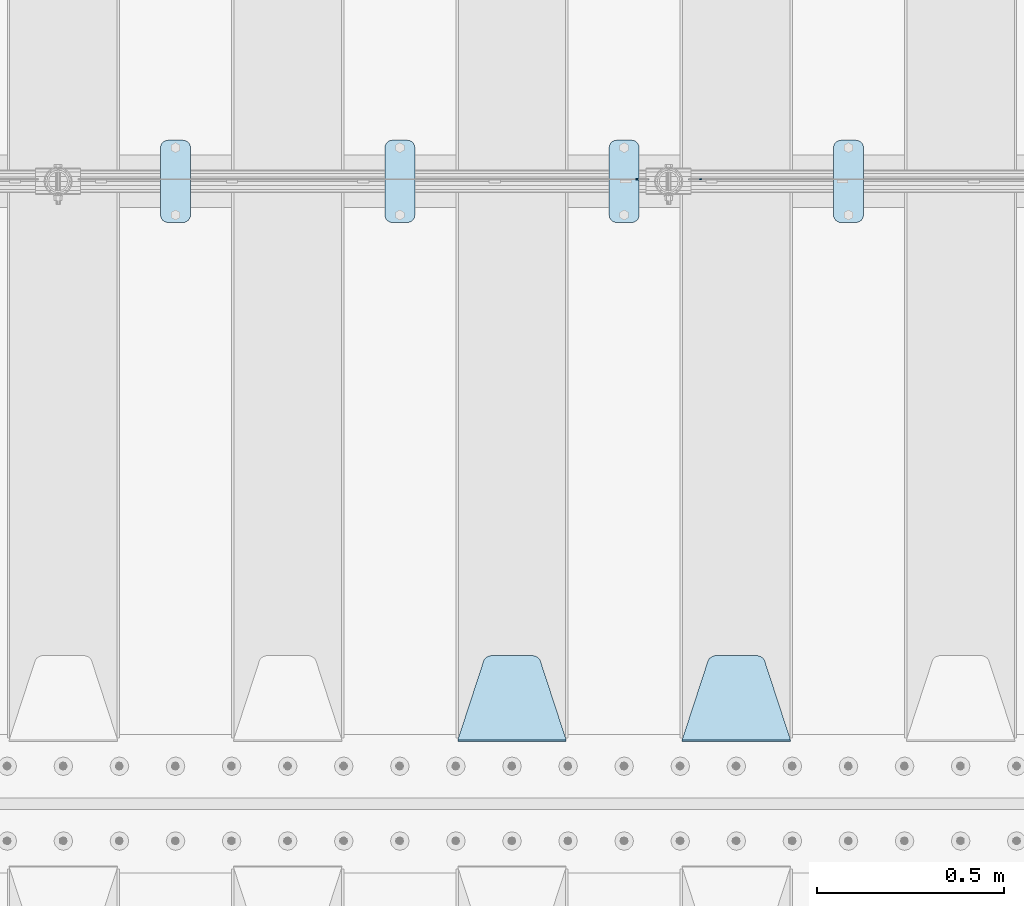
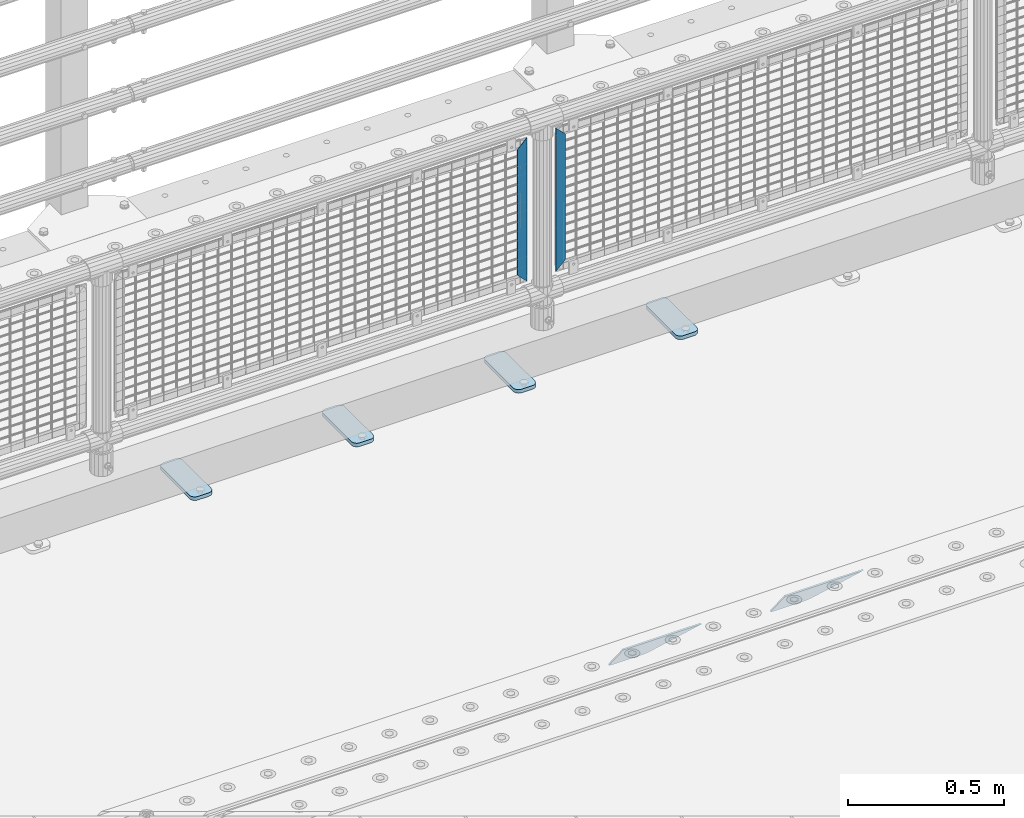
# One storey, part 211 of 242: 8 plates.
"""IFC2X3 building model written with IfcOpenShell, lengths in millimetres."""

import ifcopenshell
import ifcopenshell.guid

model = None  # the IFC model being written
_history = None  # IfcOwnerHistory: only IFC2X3 demands one
_inside = {}  # id of a spatial element -> (the spatial element, [elements in it])
_under = {}  # id of a project, library or spatial element -> (it, [spatial elements below it])
_declared = {}  # id of a project -> (the project, [libraries it declares])
_typed = {}  # id of a type object -> (the type object, [elements of that type])
_made_of = {}  # id of a material, layer set ... -> (it, [elements and type objects made of it])


def new_model(schema):
    """Start an empty IFC model of exactly this schema.

    Asked for "IFC4X3", IfcOpenShell would pick the latest addendum, in which some entities
    have other attributes; the version numbers below select the first issue.
    IFC2X3 requires an IfcOwnerHistory on every rooted entity: one is made here for all.
    """
    global model, _history
    if schema == "IFC4X3":
        model = ifcopenshell.file(schema_version=(4, 3, 0, 0))
    else:
        model = ifcopenshell.file(schema=schema)
    _inside.clear()
    _under.clear()
    _declared.clear()
    _typed.clear()
    _made_of.clear()
    _history = None
    if model.schema == "IFC2X3":
        org = make("IfcOrganization", Name="unknown")
        user = make(
            "IfcPersonAndOrganization",
            ThePerson=make("IfcPerson", FamilyName="unknown"),
            TheOrganization=org,
        )
        app = make(
            "IfcApplication",
            ApplicationDeveloper=org,
            Version="unknown",
            ApplicationFullName="unknown",
            ApplicationIdentifier="unknown",
        )
        _history = make(
            "IfcOwnerHistory",
            OwningUser=user,
            OwningApplication=app,
            ChangeAction="ADDED",
            CreationDate=0,
        )
    return model


def make(cls, **values):
    """One entity of the class cls with the attributes given. An attribute that is None is left unset."""
    return model.create_entity(
        cls, **{name: value for name, value in values.items() if value is not None}
    )


def rooted(cls, **values):
    """An entity with a GlobalId (a new one), such as an element, a storey or a relation."""
    return make(cls, GlobalId=ifcopenshell.guid.new(), OwnerHistory=_history, **values)


def si_unit(unit_type, name, prefix=None):
    """IfcSIUnit, for example si_unit("LENGTHUNIT", "METRE", prefix="MILLI")."""
    return make("IfcSIUnit", UnitType=unit_type, Prefix=prefix, Name=name)


def assignment(units):
    """IfcUnitAssignment: the units of a project."""
    return None if units is None else make("IfcUnitAssignment", Units=units)


def point(xyz):
    """IfcCartesianPoint."""
    return None if xyz is None else make("IfcCartesianPoint", Coordinates=xyz)


def direction(xyz):
    """IfcDirection."""
    return None if xyz is None else make("IfcDirection", DirectionRatios=xyz)


def frame(location, z_axis=None, x_axis=None):
    """IfcAxis2Placement3D, a coordinate frame: its origin and axes. An axis left out is left unset."""
    return make(
        "IfcAxis2Placement3D",
        Location=point(location),
        Axis=direction(z_axis),
        RefDirection=direction(x_axis),
    )


def origin_with_axes():
    """The frame at (0, 0, 0) with the z axis (0, 0, 1) and the x axis (1, 0, 0) written out."""
    return frame((0.0, 0.0, 0.0), z_axis=(0.0, 0.0, 1.0), x_axis=(1.0, 0.0, 0.0))


def place(relative_to, where):
    """IfcLocalPlacement: puts the frame where relative to a parent placement (None: the world)."""
    return make(
        "IfcLocalPlacement", PlacementRelTo=relative_to, RelativePlacement=where
    )


def context(
    kind, dimensions, precision=None, world=None, true_north=None, identifier=None
):
    """IfcGeometricRepresentationContext, for example the 3D "Model" context."""
    return make(
        "IfcGeometricRepresentationContext",
        ContextIdentifier=identifier,
        ContextType=kind,
        CoordinateSpaceDimension=dimensions,
        Precision=precision,
        WorldCoordinateSystem=world,
        TrueNorth=true_north,
    )


def subcontext(parent, identifier, kind, view, scale=None):
    """IfcGeometricRepresentationSubContext, for example "Body" below "Model"."""
    return make(
        "IfcGeometricRepresentationSubContext",
        ContextIdentifier=identifier,
        ContextType=kind,
        ParentContext=parent,
        TargetScale=scale,
        TargetView=view,
    )


def project(units=None, contexts=None):
    """IfcProject with its units and contexts."""
    return rooted(
        "IfcProject",
        Name="project",
        RepresentationContexts=contexts,
        UnitsInContext=assignment(units),
    )


def spatial(cls, under=None, at=None, **own):
    """A site, building, storey or space (cls), placed at a placement, below another one or the project."""
    s = rooted(cls, ObjectPlacement=at, **own)
    if under is not None:
        _under.setdefault(under.id(), (under, []))[1].append(s)
    return s


def faces_of(points, faces, orient=None, outer=None):
    """IfcFace entities. A face is a list of loops; a loop is a list of indices into points, from 0.

    orient and outer hold one flag for each loop. By default every Orientation is true, the
    first loop of a face is its IfcFaceOuterBound and the others are IfcFaceBound.
    """
    made = []
    for i, loops in enumerate(faces):
        bounds = []
        for j, loop in enumerate(loops):
            is_outer = j == 0 if outer is None else outer[i][j]
            bounds.append(
                make(
                    "IfcFaceOuterBound" if is_outer else "IfcFaceBound",
                    Bound=make("IfcPolyLoop", Polygon=[points[k] for k in loop]),
                    Orientation=True if orient is None else orient[i][j],
                )
            )
        made.append(make("IfcFace", Bounds=bounds))
    return made


def faceted_brep(points, faces, orient=None, outer=None, voids=None):
    """IfcFacetedBrep: a solid bounded by flat faces; with voids (closed shells), ...WithVoids."""
    shared = [point(p) for p in points]
    hull = make("IfcClosedShell", CfsFaces=faces_of(shared, faces, orient, outer))
    if voids is None:
        return make("IfcFacetedBrep", Outer=hull)
    return make(
        "IfcFacetedBrepWithVoids",
        Outer=hull,
        Voids=[
            make(cls, CfsFaces=faces_of(shared, fs, o, b)) for cls, fs, o, b in voids
        ],
    )


def shape(context_of_items, identifier, shape_type, items):
    """IfcShapeRepresentation: the items that make up one representation, for example the "Body"."""
    return make(
        "IfcShapeRepresentation",
        ContextOfItems=context_of_items,
        RepresentationIdentifier=identifier,
        RepresentationType=shape_type,
        Items=items,
    )


def material(Name=None, Category=None):
    """IfcMaterial."""
    return make("IfcMaterial", Name=Name, Category=Category)


def made_of(thing, what):
    """Note that an element or type object is made of a material, layer set ...; save() writes the relation."""
    if what is not None:
        _made_of.setdefault(what.id(), (what, []))[1].append(thing)
    return thing


def type_object(cls, material=None, **own):
    """A type object (cls), such as IfcWallType, which elements share."""
    return made_of(rooted(cls, **own), material)


def element(
    cls,
    number,
    at=None,
    inside=None,
    cuts=None,
    type_object=None,
    material=None,
    context=None,
    identifier="Body",
    shape_type=None,
    held_by="IfcProductDefinitionShape",
    body=None,
    shapes=None,
    **own,
):
    """One element of the class cls, such as IfcWall. Its Tag is "e" and its number.

    at: its placement. inside: the storey or other place that contains it. cuts: it is an
    opening in that element (IfcRelVoidsElement). A single representation is given by context,
    identifier, shape_type and body (its items); several are given by shapes. held_by: the class
    of the entity that holds the representations. save() writes the other relations.
    """
    e = rooted(cls, Tag="e%d" % number, ObjectPlacement=at, **own)
    if body is not None:
        shapes = [shape(context, identifier, shape_type, body)]
    if shapes is not None:
        e.Representation = make(held_by, Representations=shapes)
    if inside is not None:
        _inside.setdefault(inside.id(), (inside, []))[1].append(e)
    if cuts is not None:
        rooted(
            "IfcRelVoidsElement", RelatingBuildingElement=cuts, RelatedOpeningElement=e
        )
    if type_object is not None:
        _typed.setdefault(type_object.id(), (type_object, []))[1].append(e)
    return made_of(e, material)


def aggregate(whole, parts):
    """IfcRelAggregates: a whole, such as a stair, and the parts it consists of."""
    return rooted("IfcRelAggregates", RelatingObject=whole, RelatedObjects=parts)


def save(model, path):
    """Write the relations noted so far, then the file.

    IfcRelAggregates (storeys below a building ...), IfcRelContainedInSpatialStructure (elements
    in a storey), IfcRelDefinesByType, IfcRelAssociatesMaterial and IfcRelDeclares: one each for
    every whole, place, type object, material and project.
    """
    for whole, parts in _under.values():
        aggregate(whole, parts)
    for where, things in _inside.values():
        rooted(
            "IfcRelContainedInSpatialStructure",
            RelatedElements=things,
            RelatingStructure=where,
        )
    for kind, things in _typed.values():
        rooted("IfcRelDefinesByType", RelatedObjects=things, RelatingType=kind)
    for what, things in _made_of.values():
        rooted("IfcRelAssociatesMaterial", RelatedObjects=things, RelatingMaterial=what)
    for by, libraries in _declared.values():
        rooted("IfcRelDeclares", RelatingContext=by, RelatedDefinitions=libraries)
    model.write(path)


model = new_model("IFC2X3")

# Units and contexts
model_context = context("Model", 3, precision=1e-05, world=origin_with_axes())
body_context = subcontext(model_context, "Body", "Model", "MODEL_VIEW")
ifc_project = project(units=[si_unit("LENGTHUNIT", "METRE", prefix="MILLI"), si_unit("AREAUNIT", "SQUARE_METRE"), si_unit("VOLUMEUNIT", "CUBIC_METRE"), si_unit("MASSUNIT", "GRAM", prefix="KILO"), si_unit("TIMEUNIT", "SECOND"), si_unit("PLANEANGLEUNIT", "RADIAN"), si_unit("SOLIDANGLEUNIT", "STERADIAN"), si_unit("THERMODYNAMICTEMPERATUREUNIT", "DEGREE_CELSIUS"), si_unit("LUMINOUSINTENSITYUNIT", "LUMEN")], contexts=[model_context])

# Site, building, storey
site_placement = place(None, origin_with_axes())
site = spatial("IfcSite", under=ifc_project, at=site_placement, CompositionType="ELEMENT")
building_placement = place(site_placement, origin_with_axes())
building = spatial("IfcBuilding", under=site, at=building_placement, Name="Standard", CompositionType="ELEMENT")
storey_placement = place(building_placement, origin_with_axes())
storey = spatial("IfcBuildingStorey", under=building, at=storey_placement, Name="Undefined", CompositionType="ELEMENT", Elevation=0.0)

# Plates
ifc_material_1 = material(Name="Misc_Undefined")
plate_type_1 = type_object("IfcPlateType", PredefinedType="NOTDEFINED")
plate_1_placement = place(storey_placement, frame((-31942.490286459, -19329.5, 879.519963133601), z_axis=(-0.707008801899319, 0.0, -0.707204746899291), x_axis=(-0.707204746899296, 0.0, 0.707008801899313)))
element("IfcPlate", 1, at=plate_1_placement, inside=storey, type_object=plate_type_1, material=ifc_material_1, context=body_context, shape_type="Brep", body=[
    faceted_brep([(0.0, -1.50000000000364, 0.0), (-348.552185058597, -1.5, 348.655029296875), (-348.552185058597, 1.5, 348.655029296875), (-3.63797880709171e-12, 1.49999999999636, 0.0), (-348.544891357426, -1.5, 398.152496337891), (-348.544891357426, 1.5, 398.152496337891), (49.5043945312464, -1.5, 8.00355337560177e-11), (49.5043945312464, 1.5, 8.00355337560177e-11)], [[[0, 1, 2, 3]], [[1, 4, 5, 2]], [[4, 6, 7, 5]], [[6, 0, 3, 7]], [[5, 7, 3, 2]], [[6, 4, 1, 0]]]),
])
plate_2_placement = place(storey_placement, frame((-32119.5003125164, -19329.5, 879.52), z_axis=(0.707103624179499, 0.0, -0.707109938179501), x_axis=(0.707109938179508, 0.0, 0.707103624179492)))
element("IfcPlate", 2, at=plate_2_placement, inside=storey, type_object=plate_type_1, material=ifc_material_1, context=body_context, shape_type="Brep", body=[
    faceted_brep([(0.0, -1.50000000000364, 0.0), (-348.605163574222, -1.5, 348.602081298832), (-348.605163574222, 1.5, 348.602081298832), (-3.63797880709171e-12, 1.49999999999636, 0.0), (-348.605163574222, -1.5, 398.099334716801), (-348.605163574222, 1.5, 398.099334716801), (49.4976959228534, -1.5, -3.63797880709171e-12), (49.4976959228534, 1.5, -3.63797880709171e-12)], [[[0, 1, 2, 3]], [[1, 4, 5, 2]], [[4, 6, 7, 5]], [[6, 0, 3, 7]], [[5, 7, 3, 2]], [[6, 4, 1, 0]]]),
])
ifc_material_2 = material(Name="STEEL/S355J2")
plate_type_2 = type_object("IfcPlateType", PredefinedType="NOTDEFINED")
plate_3_placement = place(storey_placement, frame((-31590.0, -19225.5, 21.0199999999977), z_axis=(1.0, 0.0, 0.0), x_axis=(0.0, -1.0, 0.0)))
element("IfcPlate", 3, at=plate_3_placement, inside=storey, type_object=plate_type_2, material=ifc_material_2, context=body_context, shape_type="Brep", body=[
    faceted_brep([(0.0, -7.0, 20.0), (0.0, -7.0, 60.0), (0.0, 7.0, 60.0), (0.0, 7.0, 20.0), (0.384294391937146, -7.0, 63.9018064403208), (0.384294391937146, 7.0, 63.9018064403208), (1.52240934977453, -7.0, 67.6536686473009), (1.52240934977453, 7.0, 67.6536686473009), (3.37060775395003, -7.0, 71.1114046603907), (3.37060775395003, 7.0, 71.1114046603907), (5.8578643762703, -7.0, 74.1421356237297), (5.8578643762703, 7.0, 74.1421356237297), (8.88859533960931, -7.0, 76.62939224605), (8.88859533960931, 7.0, 76.62939224605), (12.3463313526991, -7.0, 78.4775906502255), (12.3463313526991, 7.0, 78.4775906502255), (16.0981935596792, -7.0, 79.6157056080629), (16.0981935596792, 7.0, 79.6157056080629), (20.0, -7.0, 80.0), (20.0, 7.0, 80.0), (200.0, -7.0, 80.0), (200.0, 7.0, 80.0), (203.901806440321, -7.0, 79.6157056080629), (203.901806440321, 7.0, 79.6157056080629), (207.653668647301, -7.0, 78.4775906502255), (207.653668647301, 7.0, 78.4775906502255), (211.111404660391, -7.0, 76.62939224605), (211.111404660391, 7.0, 76.62939224605), (214.14213562373, -7.0, 74.1421356237297), (214.14213562373, 7.0, 74.1421356237297), (216.62939224605, -7.0, 71.1114046603907), (216.62939224605, 7.0, 71.1114046603907), (218.477590650225, -7.0, 67.6536686473009), (218.477590650225, 7.0, 67.6536686473009), (219.615705608063, -7.0, 63.9018064403208), (219.615705608063, 7.0, 63.9018064403208), (220.0, -7.0, 60.0), (220.0, 7.0, 60.0), (220.0, -7.0, 20.0), (220.0, 7.0, 20.0), (219.615705608063, -7.0, 16.0981935596792), (219.615705608063, 7.0, 16.0981935596792), (218.477590650225, -7.0, 12.3463313526991), (218.477590650225, 7.0, 12.3463313526991), (216.62939224605, -7.0, 8.88859533960931), (216.62939224605, 7.0, 8.88859533960931), (214.14213562373, -7.0, 5.8578643762703), (214.14213562373, 7.0, 5.8578643762703), (211.111404660391, -7.0, 3.37060775395003), (211.111404660391, 7.0, 3.37060775395003), (207.653668647301, -7.0, 1.52240934977453), (207.653668647301, 7.0, 1.52240934977453), (203.901806440321, -7.0, 0.384294391937146), (203.901806440321, 7.0, 0.384294391937146), (200.0, -7.0, 0.0), (200.0, 7.0, 0.0), (20.0, -7.0, 0.0), (20.0, 7.0, 0.0), (16.0981935596792, -7.0, 0.384294391937146), (16.0981935596792, 7.0, 0.384294391937146), (12.3463313526991, -7.0, 1.52240934977453), (12.3463313526991, 7.0, 1.52240934977453), (8.88859533960931, -7.0, 3.37060775395003), (8.88859533960931, 7.0, 3.37060775395003), (5.8578643762703, -7.0, 5.8578643762703), (5.8578643762703, 7.0, 5.8578643762703), (3.37060775395003, -7.0, 8.88859533960931), (3.37060775395003, 7.0, 8.88859533960931), (1.52240934977453, -7.0, 12.3463313526991), (1.52240934977453, 7.0, 12.3463313526991), (0.384294391937146, -7.0, 16.0981935596792), (0.384294391937146, 7.0, 16.0981935596792)], [[[0, 1, 2, 3]], [[1, 4, 5, 2]], [[4, 6, 7, 5]], [[6, 8, 9, 7]], [[8, 10, 11, 9]], [[10, 12, 13, 11]], [[12, 14, 15, 13]], [[14, 16, 17, 15]], [[16, 18, 19, 17]], [[18, 20, 21, 19]], [[20, 22, 23, 21]], [[22, 24, 25, 23]], [[24, 26, 27, 25]], [[26, 28, 29, 27]], [[28, 30, 31, 29]], [[30, 32, 33, 31]], [[32, 34, 35, 33]], [[34, 36, 37, 35]], [[36, 38, 39, 37]], [[38, 40, 41, 39]], [[40, 42, 43, 41]], [[42, 44, 45, 43]], [[44, 46, 47, 45]], [[46, 48, 49, 47]], [[48, 50, 51, 49]], [[50, 52, 53, 51]], [[52, 54, 55, 53]], [[54, 56, 57, 55]], [[56, 58, 59, 57]], [[58, 60, 61, 59]], [[60, 62, 63, 61]], [[62, 64, 65, 63]], [[64, 66, 67, 65]], [[66, 68, 69, 67]], [[68, 70, 71, 69]], [[70, 0, 3, 71]], [[5, 7, 9, 11, 13, 15, 17, 19, 21, 23, 25, 27, 29, 31, 33, 35, 37, 39, 41, 43, 45, 47, 49, 51, 53, 55, 57, 59, 61, 63, 65, 67, 69, 71, 3, 2]], [[70, 68, 66, 64, 62, 60, 58, 56, 54, 52, 50, 48, 46, 44, 42, 40, 38, 36, 34, 32, 30, 28, 26, 24, 22, 20, 18, 16, 14, 12, 10, 8, 6, 4, 1, 0]]]),
])
plate_4_placement = place(storey_placement, frame((-32190.0, -19225.5, 21.0199999999977), z_axis=(1.0, 0.0, 0.0), x_axis=(0.0, -1.0, 0.0)))
element("IfcPlate", 4, at=plate_4_placement, inside=storey, type_object=plate_type_2, material=ifc_material_2, context=body_context, shape_type="Brep", body=[
    faceted_brep([(0.0, -7.0, 20.0), (0.0, -7.0, 60.0), (0.0, 7.0, 60.0), (0.0, 7.0, 20.0), (0.384294391937146, -7.0, 63.9018064403208), (0.384294391937146, 7.0, 63.9018064403208), (1.52240934977453, -7.0, 67.6536686473009), (1.52240934977453, 7.0, 67.6536686473009), (3.37060775395003, -7.0, 71.1114046603907), (3.37060775395003, 7.0, 71.1114046603907), (5.8578643762703, -7.0, 74.1421356237297), (5.8578643762703, 7.0, 74.1421356237297), (8.88859533960931, -7.0, 76.62939224605), (8.88859533960931, 7.0, 76.62939224605), (12.3463313526991, -7.0, 78.4775906502255), (12.3463313526991, 7.0, 78.4775906502255), (16.0981935596792, -7.0, 79.6157056080629), (16.0981935596792, 7.0, 79.6157056080629), (20.0, -7.0, 80.0), (20.0, 7.0, 80.0), (200.0, -7.0, 80.0), (200.0, 7.0, 80.0), (203.901806440321, -7.0, 79.6157056080629), (203.901806440321, 7.0, 79.6157056080629), (207.653668647301, -7.0, 78.4775906502255), (207.653668647301, 7.0, 78.4775906502255), (211.111404660391, -7.0, 76.62939224605), (211.111404660391, 7.0, 76.62939224605), (214.14213562373, -7.0, 74.1421356237297), (214.14213562373, 7.0, 74.1421356237297), (216.62939224605, -7.0, 71.1114046603907), (216.62939224605, 7.0, 71.1114046603907), (218.477590650225, -7.0, 67.6536686473009), (218.477590650225, 7.0, 67.6536686473009), (219.615705608063, -7.0, 63.9018064403208), (219.615705608063, 7.0, 63.9018064403208), (220.0, -7.0, 60.0), (220.0, 7.0, 60.0), (220.0, -7.0, 20.0), (220.0, 7.0, 20.0), (219.615705608063, -7.0, 16.0981935596792), (219.615705608063, 7.0, 16.0981935596792), (218.477590650225, -7.0, 12.3463313526991), (218.477590650225, 7.0, 12.3463313526991), (216.62939224605, -7.0, 8.88859533960931), (216.62939224605, 7.0, 8.88859533960931), (214.14213562373, -7.0, 5.8578643762703), (214.14213562373, 7.0, 5.8578643762703), (211.111404660391, -7.0, 3.37060775395003), (211.111404660391, 7.0, 3.37060775395003), (207.653668647301, -7.0, 1.52240934977453), (207.653668647301, 7.0, 1.52240934977453), (203.901806440321, -7.0, 0.384294391937146), (203.901806440321, 7.0, 0.384294391937146), (200.0, -7.0, 0.0), (200.0, 7.0, 0.0), (20.0, -7.0, 0.0), (20.0, 7.0, 0.0), (16.0981935596792, -7.0, 0.384294391937146), (16.0981935596792, 7.0, 0.384294391937146), (12.3463313526991, -7.0, 1.52240934977453), (12.3463313526991, 7.0, 1.52240934977453), (8.88859533960931, -7.0, 3.37060775395003), (8.88859533960931, 7.0, 3.37060775395003), (5.8578643762703, -7.0, 5.8578643762703), (5.8578643762703, 7.0, 5.8578643762703), (3.37060775395003, -7.0, 8.88859533960931), (3.37060775395003, 7.0, 8.88859533960931), (1.52240934977453, -7.0, 12.3463313526991), (1.52240934977453, 7.0, 12.3463313526991), (0.384294391937146, -7.0, 16.0981935596792), (0.384294391937146, 7.0, 16.0981935596792)], [[[0, 1, 2, 3]], [[1, 4, 5, 2]], [[4, 6, 7, 5]], [[6, 8, 9, 7]], [[8, 10, 11, 9]], [[10, 12, 13, 11]], [[12, 14, 15, 13]], [[14, 16, 17, 15]], [[16, 18, 19, 17]], [[18, 20, 21, 19]], [[20, 22, 23, 21]], [[22, 24, 25, 23]], [[24, 26, 27, 25]], [[26, 28, 29, 27]], [[28, 30, 31, 29]], [[30, 32, 33, 31]], [[32, 34, 35, 33]], [[34, 36, 37, 35]], [[36, 38, 39, 37]], [[38, 40, 41, 39]], [[40, 42, 43, 41]], [[42, 44, 45, 43]], [[44, 46, 47, 45]], [[46, 48, 49, 47]], [[48, 50, 51, 49]], [[50, 52, 53, 51]], [[52, 54, 55, 53]], [[54, 56, 57, 55]], [[56, 58, 59, 57]], [[58, 60, 61, 59]], [[60, 62, 63, 61]], [[62, 64, 65, 63]], [[64, 66, 67, 65]], [[66, 68, 69, 67]], [[68, 70, 71, 69]], [[70, 0, 3, 71]], [[5, 7, 9, 11, 13, 15, 17, 19, 21, 23, 25, 27, 29, 31, 33, 35, 37, 39, 41, 43, 45, 47, 49, 51, 53, 55, 57, 59, 61, 63, 65, 67, 69, 71, 3, 2]], [[70, 68, 66, 64, 62, 60, 58, 56, 54, 52, 50, 48, 46, 44, 42, 40, 38, 36, 34, 32, 30, 28, 26, 24, 22, 20, 18, 16, 14, 12, 10, 8, 6, 4, 1, 0]]]),
])
plate_5_placement = place(storey_placement, frame((-32790.0, -19225.5, 21.0199999999977), z_axis=(1.0, 0.0, 0.0), x_axis=(0.0, -1.0, 0.0)))
element("IfcPlate", 5, at=plate_5_placement, inside=storey, type_object=plate_type_2, material=ifc_material_2, context=body_context, shape_type="Brep", body=[
    faceted_brep([(0.0, -7.0, 20.0), (0.0, -7.0, 60.0), (0.0, 7.0, 60.0), (0.0, 7.0, 20.0), (0.384294391937146, -7.0, 63.9018064403208), (0.384294391937146, 7.0, 63.9018064403208), (1.52240934977453, -7.0, 67.6536686473009), (1.52240934977453, 7.0, 67.6536686473009), (3.37060775395003, -7.0, 71.1114046603907), (3.37060775395003, 7.0, 71.1114046603907), (5.8578643762703, -7.0, 74.1421356237297), (5.8578643762703, 7.0, 74.1421356237297), (8.88859533960931, -7.0, 76.62939224605), (8.88859533960931, 7.0, 76.62939224605), (12.3463313526991, -7.0, 78.4775906502255), (12.3463313526991, 7.0, 78.4775906502255), (16.0981935596792, -7.0, 79.6157056080629), (16.0981935596792, 7.0, 79.6157056080629), (20.0, -7.0, 80.0), (20.0, 7.0, 80.0), (200.0, -7.0, 80.0), (200.0, 7.0, 80.0), (203.901806440321, -7.0, 79.6157056080629), (203.901806440321, 7.0, 79.6157056080629), (207.653668647301, -7.0, 78.4775906502255), (207.653668647301, 7.0, 78.4775906502255), (211.111404660391, -7.0, 76.62939224605), (211.111404660391, 7.0, 76.62939224605), (214.14213562373, -7.0, 74.1421356237297), (214.14213562373, 7.0, 74.1421356237297), (216.62939224605, -7.0, 71.1114046603907), (216.62939224605, 7.0, 71.1114046603907), (218.477590650225, -7.0, 67.6536686473009), (218.477590650225, 7.0, 67.6536686473009), (219.615705608063, -7.0, 63.9018064403208), (219.615705608063, 7.0, 63.9018064403208), (220.0, -7.0, 60.0), (220.0, 7.0, 60.0), (220.0, -7.0, 20.0), (220.0, 7.0, 20.0), (219.615705608063, -7.0, 16.0981935596792), (219.615705608063, 7.0, 16.0981935596792), (218.477590650225, -7.0, 12.3463313526991), (218.477590650225, 7.0, 12.3463313526991), (216.62939224605, -7.0, 8.88859533960931), (216.62939224605, 7.0, 8.88859533960931), (214.14213562373, -7.0, 5.8578643762703), (214.14213562373, 7.0, 5.8578643762703), (211.111404660391, -7.0, 3.37060775395003), (211.111404660391, 7.0, 3.37060775395003), (207.653668647301, -7.0, 1.52240934977453), (207.653668647301, 7.0, 1.52240934977453), (203.901806440321, -7.0, 0.384294391937146), (203.901806440321, 7.0, 0.384294391937146), (200.0, -7.0, 0.0), (200.0, 7.0, 0.0), (20.0, -7.0, 0.0), (20.0, 7.0, 0.0), (16.0981935596792, -7.0, 0.384294391937146), (16.0981935596792, 7.0, 0.384294391937146), (12.3463313526991, -7.0, 1.52240934977453), (12.3463313526991, 7.0, 1.52240934977453), (8.88859533960931, -7.0, 3.37060775395003), (8.88859533960931, 7.0, 3.37060775395003), (5.8578643762703, -7.0, 5.8578643762703), (5.8578643762703, 7.0, 5.8578643762703), (3.37060775395003, -7.0, 8.88859533960931), (3.37060775395003, 7.0, 8.88859533960931), (1.52240934977453, -7.0, 12.3463313526991), (1.52240934977453, 7.0, 12.3463313526991), (0.384294391937146, -7.0, 16.0981935596792), (0.384294391937146, 7.0, 16.0981935596792)], [[[0, 1, 2, 3]], [[1, 4, 5, 2]], [[4, 6, 7, 5]], [[6, 8, 9, 7]], [[8, 10, 11, 9]], [[10, 12, 13, 11]], [[12, 14, 15, 13]], [[14, 16, 17, 15]], [[16, 18, 19, 17]], [[18, 20, 21, 19]], [[20, 22, 23, 21]], [[22, 24, 25, 23]], [[24, 26, 27, 25]], [[26, 28, 29, 27]], [[28, 30, 31, 29]], [[30, 32, 33, 31]], [[32, 34, 35, 33]], [[34, 36, 37, 35]], [[36, 38, 39, 37]], [[38, 40, 41, 39]], [[40, 42, 43, 41]], [[42, 44, 45, 43]], [[44, 46, 47, 45]], [[46, 48, 49, 47]], [[48, 50, 51, 49]], [[50, 52, 53, 51]], [[52, 54, 55, 53]], [[54, 56, 57, 55]], [[56, 58, 59, 57]], [[58, 60, 61, 59]], [[60, 62, 63, 61]], [[62, 64, 65, 63]], [[64, 66, 67, 65]], [[66, 68, 69, 67]], [[68, 70, 71, 69]], [[70, 0, 3, 71]], [[5, 7, 9, 11, 13, 15, 17, 19, 21, 23, 25, 27, 29, 31, 33, 35, 37, 39, 41, 43, 45, 47, 49, 51, 53, 55, 57, 59, 61, 63, 65, 67, 69, 71, 3, 2]], [[70, 68, 66, 64, 62, 60, 58, 56, 54, 52, 50, 48, 46, 44, 42, 40, 38, 36, 34, 32, 30, 28, 26, 24, 22, 20, 18, 16, 14, 12, 10, 8, 6, 4, 1, 0]]]),
])
plate_6_placement = place(storey_placement, frame((-33390.0, -19225.5, 21.0199999999977), z_axis=(1.0, 0.0, 0.0), x_axis=(0.0, -1.0, 0.0)))
element("IfcPlate", 6, at=plate_6_placement, inside=storey, type_object=plate_type_2, material=ifc_material_2, context=body_context, shape_type="Brep", body=[
    faceted_brep([(0.0, -7.0, 20.0), (0.0, -7.0, 60.0), (0.0, 7.0, 60.0), (0.0, 7.0, 20.0), (0.384294391937146, -7.0, 63.9018064403208), (0.384294391937146, 7.0, 63.9018064403208), (1.52240934977453, -7.0, 67.6536686473009), (1.52240934977453, 7.0, 67.6536686473009), (3.37060775395003, -7.0, 71.1114046603907), (3.37060775395003, 7.0, 71.1114046603907), (5.8578643762703, -7.0, 74.1421356237297), (5.8578643762703, 7.0, 74.1421356237297), (8.88859533960931, -7.0, 76.62939224605), (8.88859533960931, 7.0, 76.62939224605), (12.3463313526991, -7.0, 78.4775906502255), (12.3463313526991, 7.0, 78.4775906502255), (16.0981935596792, -7.0, 79.6157056080629), (16.0981935596792, 7.0, 79.6157056080629), (20.0, -7.0, 80.0), (20.0, 7.0, 80.0), (200.0, -7.0, 80.0), (200.0, 7.0, 80.0), (203.901806440321, -7.0, 79.6157056080629), (203.901806440321, 7.0, 79.6157056080629), (207.653668647301, -7.0, 78.4775906502255), (207.653668647301, 7.0, 78.4775906502255), (211.111404660391, -7.0, 76.62939224605), (211.111404660391, 7.0, 76.62939224605), (214.14213562373, -7.0, 74.1421356237297), (214.14213562373, 7.0, 74.1421356237297), (216.62939224605, -7.0, 71.1114046603907), (216.62939224605, 7.0, 71.1114046603907), (218.477590650225, -7.0, 67.6536686473009), (218.477590650225, 7.0, 67.6536686473009), (219.615705608063, -7.0, 63.9018064403208), (219.615705608063, 7.0, 63.9018064403208), (220.0, -7.0, 60.0), (220.0, 7.0, 60.0), (220.0, -7.0, 20.0), (220.0, 7.0, 20.0), (219.615705608063, -7.0, 16.0981935596792), (219.615705608063, 7.0, 16.0981935596792), (218.477590650225, -7.0, 12.3463313526991), (218.477590650225, 7.0, 12.3463313526991), (216.62939224605, -7.0, 8.88859533960931), (216.62939224605, 7.0, 8.88859533960931), (214.14213562373, -7.0, 5.8578643762703), (214.14213562373, 7.0, 5.8578643762703), (211.111404660391, -7.0, 3.37060775395003), (211.111404660391, 7.0, 3.37060775395003), (207.653668647301, -7.0, 1.52240934977453), (207.653668647301, 7.0, 1.52240934977453), (203.901806440321, -7.0, 0.384294391937146), (203.901806440321, 7.0, 0.384294391937146), (200.0, -7.0, 0.0), (200.0, 7.0, 0.0), (20.0, -7.0, 0.0), (20.0, 7.0, 0.0), (16.0981935596792, -7.0, 0.384294391937146), (16.0981935596792, 7.0, 0.384294391937146), (12.3463313526991, -7.0, 1.52240934977453), (12.3463313526991, 7.0, 1.52240934977453), (8.88859533960931, -7.0, 3.37060775395003), (8.88859533960931, 7.0, 3.37060775395003), (5.8578643762703, -7.0, 5.8578643762703), (5.8578643762703, 7.0, 5.8578643762703), (3.37060775395003, -7.0, 8.88859533960931), (3.37060775395003, 7.0, 8.88859533960931), (1.52240934977453, -7.0, 12.3463313526991), (1.52240934977453, 7.0, 12.3463313526991), (0.384294391937146, -7.0, 16.0981935596792), (0.384294391937146, 7.0, 16.0981935596792)], [[[0, 1, 2, 3]], [[1, 4, 5, 2]], [[4, 6, 7, 5]], [[6, 8, 9, 7]], [[8, 10, 11, 9]], [[10, 12, 13, 11]], [[12, 14, 15, 13]], [[14, 16, 17, 15]], [[16, 18, 19, 17]], [[18, 20, 21, 19]], [[20, 22, 23, 21]], [[22, 24, 25, 23]], [[24, 26, 27, 25]], [[26, 28, 29, 27]], [[28, 30, 31, 29]], [[30, 32, 33, 31]], [[32, 34, 35, 33]], [[34, 36, 37, 35]], [[36, 38, 39, 37]], [[38, 40, 41, 39]], [[40, 42, 43, 41]], [[42, 44, 45, 43]], [[44, 46, 47, 45]], [[46, 48, 49, 47]], [[48, 50, 51, 49]], [[50, 52, 53, 51]], [[52, 54, 55, 53]], [[54, 56, 57, 55]], [[56, 58, 59, 57]], [[58, 60, 61, 59]], [[60, 62, 63, 61]], [[62, 64, 65, 63]], [[64, 66, 67, 65]], [[66, 68, 69, 67]], [[68, 70, 71, 69]], [[70, 0, 3, 71]], [[5, 7, 9, 11, 13, 15, 17, 19, 21, 23, 25, 27, 29, 31, 33, 35, 37, 39, 41, 43, 45, 47, 49, 51, 53, 55, 57, 59, 61, 63, 65, 67, 69, 71, 3, 2]], [[70, 68, 66, 64, 62, 60, 58, 56, 54, 52, 50, 48, 46, 44, 42, 40, 38, 36, 34, 32, 30, 28, 26, 24, 22, 20, 18, 16, 14, 12, 10, 8, 6, 4, 1, 0]]]),
])
ifc_material_3 = material(Name="STEEL/S355N")
plate_type_3 = type_object("IfcPlateType", PredefinedType="NOTDEFINED")
plate_7_placement = place(storey_placement, frame((-31705.0, -20831.767766953, -1.76776695296758), z_axis=(0.0, 0.707106781186547, -0.707106781186548), x_axis=(-1.0, 0.0, 0.0)))
element("IfcPlate", 7, at=plate_7_placement, inside=storey, type_object=plate_type_3, material=ifc_material_3, context=body_context, shape_type="Brep", body=[
    faceted_brep([(0.0, -2.5, 0.0), (69.345504679477, -2.50000000000182, 300.171731424829), (69.345504679477, 2.5, 300.171731424829), (0.0, 2.5, 0.0), (70.9274061199576, -2.5, 304.897442415398), (70.9274061199576, 2.5, 304.897442415398), (73.3818627772307, -2.5, 309.234538108525), (73.3818627772307, 2.50000000000182, 309.234538108529), (76.6187032999551, -2.5, 313.023683126101), (76.6187032999551, 2.50000000000182, 313.023683126103), (80.5190132704993, -2.5, 316.12567259537), (80.5190132704993, 2.5, 316.12567259537), (84.9395038596849, -2.5, 318.426546230474), (84.9395038596849, 2.50000000000182, 318.426546230476), (89.7177759439219, -2.49999999999818, 319.841774983273), (89.7177759439219, 2.50000000000182, 319.841774983273), (94.678286292652, -2.5, 320.319366455076), (94.678286292652, 2.5, 320.319366455076), (195.321713707348, -2.5, 320.319366455076), (195.321713707348, 2.5, 320.319366455076), (200.282224056078, -2.5, 319.841774983272), (200.282224056078, 2.50000000000182, 319.841774983273), (205.060496140315, -2.5, 318.426546230474), (205.060496140315, 2.49999999999818, 318.426546230474), (209.480986729501, -2.49999999999818, 316.12567259537), (209.480986729501, 2.5, 316.12567259537), (213.381296700045, -2.5, 313.023683126101), (213.381296700045, 2.49999999999818, 313.023683126101), (216.618137222769, -2.5, 309.234538108525), (216.618137222769, 2.5, 309.234538108523), (219.072593880042, -2.49999999999818, 304.897442415398), (219.072593880042, 2.50000000000182, 304.897442415398), (220.654495320523, -2.50000000000182, 300.171731424829), (220.654495320523, 2.5, 300.171731424829), (290.0, -2.5, 0.0), (290.0, 2.5, -1.81898940354586e-12)], [[[0, 1, 2, 3]], [[1, 4, 5, 2]], [[4, 6, 7, 5]], [[6, 8, 9, 7]], [[8, 10, 11, 9]], [[10, 12, 13, 11]], [[12, 14, 15, 13]], [[14, 16, 17, 15]], [[16, 18, 19, 17]], [[18, 20, 21, 19]], [[20, 22, 23, 21]], [[22, 24, 25, 23]], [[24, 26, 27, 25]], [[26, 28, 29, 27]], [[28, 30, 31, 29]], [[30, 32, 33, 31]], [[32, 34, 35, 33]], [[34, 0, 3, 35]], [[5, 7, 9, 11, 13, 15, 17, 19, 21, 23, 25, 27, 29, 31, 33, 35, 3, 2]], [[34, 32, 30, 28, 26, 24, 22, 20, 18, 16, 14, 12, 10, 8, 6, 4, 1, 0]]]),
])
plate_8_placement = place(storey_placement, frame((-32305.0, -20831.767766953, -1.76776695296758), z_axis=(0.0, 0.707106781186547, -0.707106781186548), x_axis=(-1.0, 0.0, 0.0)))
element("IfcPlate", 8, at=plate_8_placement, inside=storey, type_object=plate_type_3, material=ifc_material_3, context=body_context, shape_type="Brep", body=[
    faceted_brep([(0.0, -2.5, 0.0), (69.345504679477, -2.50000000000182, 300.171731424829), (69.345504679477, 2.5, 300.171731424829), (0.0, 2.5, 0.0), (70.9274061199576, -2.5, 304.897442415398), (70.9274061199576, 2.5, 304.897442415398), (73.3818627772307, -2.5, 309.234538108525), (73.3818627772307, 2.50000000000182, 309.234538108529), (76.6187032999551, -2.5, 313.023683126101), (76.6187032999551, 2.50000000000182, 313.023683126103), (80.5190132704993, -2.5, 316.12567259537), (80.5190132704993, 2.5, 316.12567259537), (84.9395038596849, -2.5, 318.426546230474), (84.9395038596849, 2.50000000000182, 318.426546230476), (89.7177759439219, -2.49999999999818, 319.841774983273), (89.7177759439219, 2.50000000000182, 319.841774983273), (94.678286292652, -2.5, 320.319366455076), (94.678286292652, 2.5, 320.319366455076), (195.321713707348, -2.5, 320.319366455076), (195.321713707348, 2.5, 320.319366455076), (200.282224056078, -2.5, 319.841774983272), (200.282224056078, 2.50000000000182, 319.841774983273), (205.060496140315, -2.5, 318.426546230474), (205.060496140315, 2.49999999999818, 318.426546230474), (209.480986729501, -2.49999999999818, 316.12567259537), (209.480986729501, 2.5, 316.12567259537), (213.381296700045, -2.5, 313.023683126101), (213.381296700045, 2.49999999999818, 313.023683126101), (216.618137222769, -2.5, 309.234538108525), (216.618137222769, 2.5, 309.234538108523), (219.072593880042, -2.49999999999818, 304.897442415398), (219.072593880042, 2.50000000000182, 304.897442415398), (220.654495320523, -2.50000000000182, 300.171731424829), (220.654495320523, 2.5, 300.171731424829), (290.0, -2.5, 0.0), (290.0, 2.5, -1.81898940354586e-12)], [[[0, 1, 2, 3]], [[1, 4, 5, 2]], [[4, 6, 7, 5]], [[6, 8, 9, 7]], [[8, 10, 11, 9]], [[10, 12, 13, 11]], [[12, 14, 15, 13]], [[14, 16, 17, 15]], [[16, 18, 19, 17]], [[18, 20, 21, 19]], [[20, 22, 23, 21]], [[22, 24, 25, 23]], [[24, 26, 27, 25]], [[26, 28, 29, 27]], [[28, 30, 31, 29]], [[30, 32, 33, 31]], [[32, 34, 35, 33]], [[34, 0, 3, 35]], [[5, 7, 9, 11, 13, 15, 17, 19, 21, 23, 25, 27, 29, 31, 33, 35, 3, 2]], [[34, 32, 30, 28, 26, 24, 22, 20, 18, 16, 14, 12, 10, 8, 6, 4, 1, 0]]]),
])

save(model, "model.ifc")
